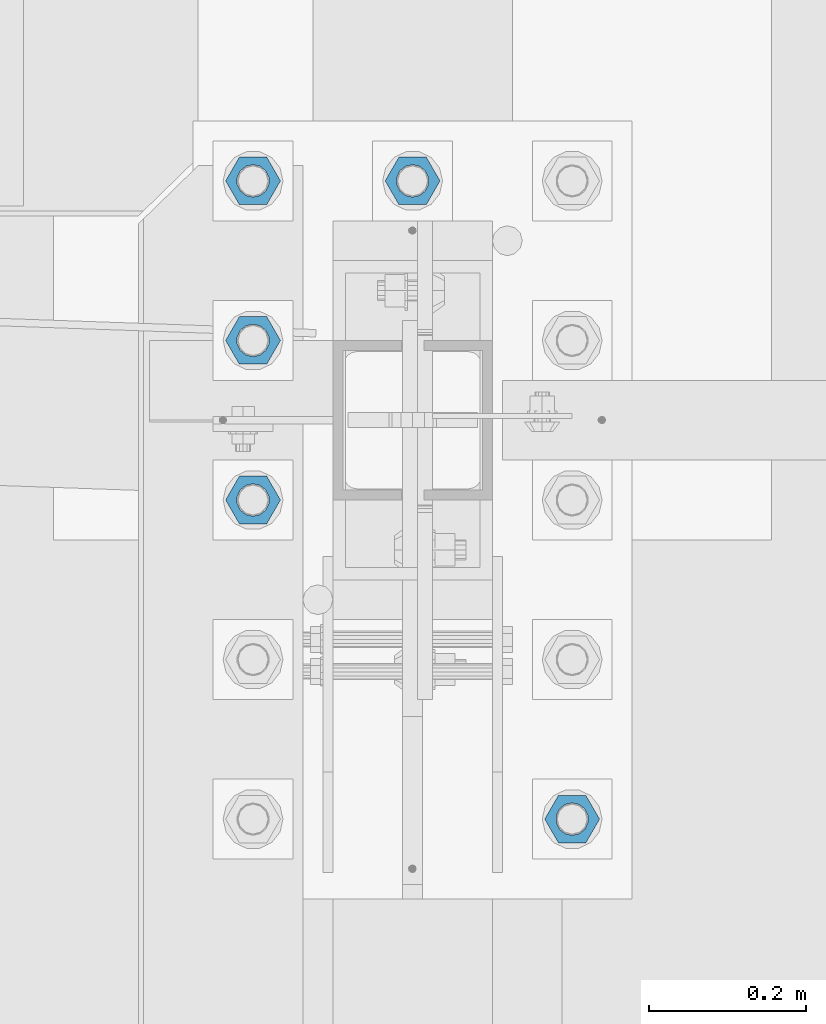
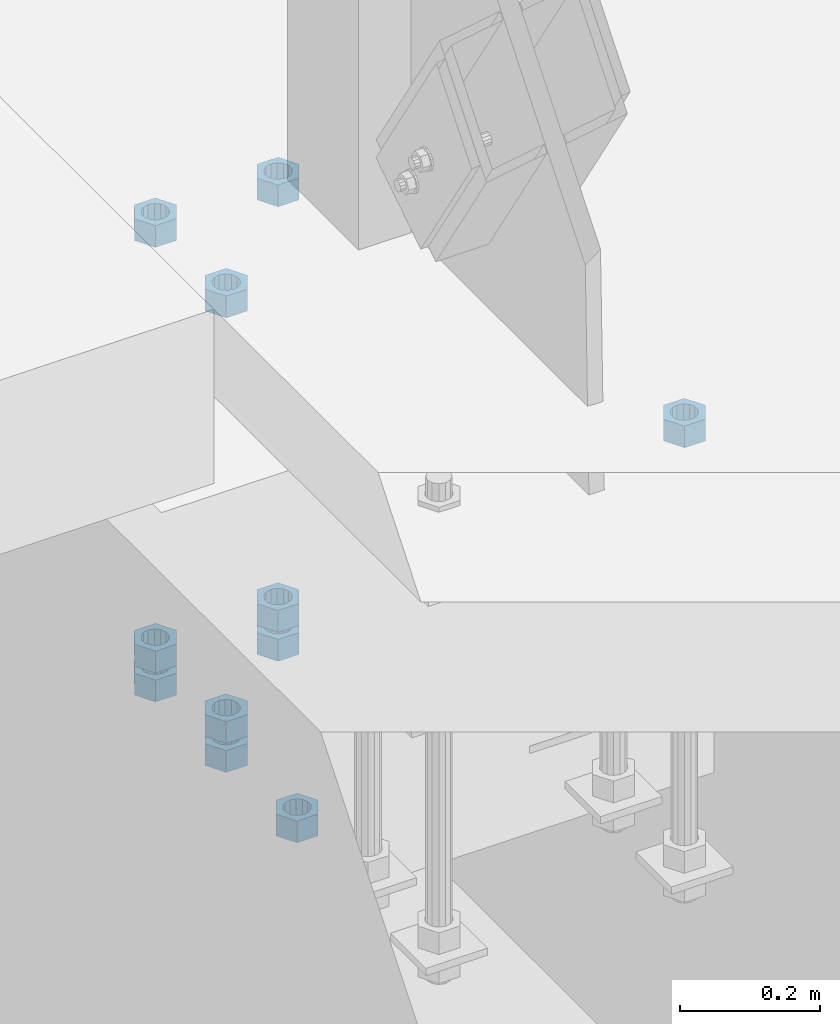
# One storey, part 988 of 1763: 11 columns, 1 element without a shape of its own.
"""IFC2X3 building model written with IfcOpenShell, lengths in millimetres."""

from ifc_helpers import new_model, si_unit, frame, origin_with_axes, place, context, subcontext, project, spatial, faceted_brep, material, type_object, element, aggregate, save


model = new_model("IFC2X3")

# Units and contexts
model_context = context("Model", 3, precision=1e-05, world=origin_with_axes())
body_context = subcontext(model_context, "Body", "Model", "MODEL_VIEW")
ifc_project = project(units=[si_unit("LENGTHUNIT", "METRE", prefix="MILLI"), si_unit("AREAUNIT", "SQUARE_METRE"), si_unit("VOLUMEUNIT", "CUBIC_METRE"), si_unit("MASSUNIT", "GRAM", prefix="KILO"), si_unit("TIMEUNIT", "SECOND"), si_unit("PLANEANGLEUNIT", "RADIAN"), si_unit("SOLIDANGLEUNIT", "STERADIAN"), si_unit("THERMODYNAMICTEMPERATUREUNIT", "DEGREE_CELSIUS"), si_unit("LUMINOUSINTENSITYUNIT", "LUMEN")], contexts=[model_context])

# Site, building, storey
site_placement = place(None, origin_with_axes())
site = spatial("IfcSite", under=ifc_project, at=site_placement, CompositionType="ELEMENT")
building_placement = place(site_placement, origin_with_axes())
building = spatial("IfcBuilding", under=site, at=building_placement, Name="Undefined", CompositionType="ELEMENT")
storey_placement = place(building_placement, origin_with_axes())
storey = spatial("IfcBuildingStorey", under=building, at=storey_placement, Name="Undefined", CompositionType="ELEMENT", Elevation=0.0)

# Assembly, columns
assembly_placement = place(storey_placement, origin_with_axes())
assembly = element("IfcElementAssembly", 1, at=assembly_placement, inside=storey, Name="TEMPLATE", AssemblyPlace="NOTDEFINED", PredefinedType="RIGID_FRAME")
ifc_material = material(Name="STEEL/A563")
column_type = type_object("IfcColumnType", Name="1-1/2_HEAVY_HEX_NUT", PredefinedType="NOTDEFINED")
column_1_placement = place(assembly_placement, frame((-87172.2372736984, 8026.40000000001, 5189.53750000001), z_axis=(0.0, 1.0, 0.0), x_axis=(0.0, 0.0, -1.0)))
column_1 = element("IfcColumn", 2, at=column_1_placement, type_object=column_type, material=ifc_material, Name="NUT", ObjectType="1-1/2_HEAVY_HEX_NUT", context=body_context, shape_type="Brep", body=[
    faceted_brep([(0.0, -34.9199981689453, 0.0), (0.0, -17.4599990844727, -30.25), (38.1000000000004, -17.4599990844727, -30.25), (38.1000000000004, -34.9199981689453, 0.0), (0.0, 17.4599990844727, -30.25), (38.1000000000004, 17.4599990844727, -30.25), (0.0, 34.9199981689453, 0.0), (38.1000000000004, 34.9199981689453, 0.0), (0.0, 17.4599990844727, 30.25), (38.1000000000004, 17.4599990844727, 30.25), (0.0, -17.4599990844727, 30.25), (38.1000000000004, -17.4599990844727, 30.25), (0.0, 0.0, 20.6399993896484), (0.0, 8.95536011056538, 18.5959968835978), (38.1000000000004, 8.95536011056538, 18.5959968835978), (38.1000000000004, 0.0, 20.6399993896484), (0.0, 16.1370013209453, 12.8688291298167), (38.1000000000004, 16.1370013209453, 12.8688291298167), (0.0, 20.1225115123816, 4.59283194104137), (38.1000000000004, 20.1225115123816, 4.59283194104137), (0.0, 20.1225115123816, -4.59283194104319), (38.1000000000004, 20.1225115123816, -4.59283194104319), (0.0, 16.1370013209453, -12.8688291298167), (38.1000000000004, 16.1370013209453, -12.8688291298167), (0.0, 8.95536011056538, -18.5959968835978), (38.1000000000004, 8.95536011056538, -18.5959968835978), (0.0, 0.0, -20.6399993896484), (38.1000000000004, 0.0, -20.6399993896484), (0.0, -8.95536011056538, -18.5959968835978), (38.1000000000004, -8.95536011056538, -18.5959968835978), (0.0, -16.1370013209453, -12.8688291298167), (38.1000000000004, -16.1370013209453, -12.8688291298167), (0.0, -20.1225115123816, -4.59283194104137), (38.1000000000004, -20.1225115123816, -4.59283194104137), (0.0, -20.1225115123816, 4.59283194104319), (38.1000000000004, -20.1225115123816, 4.59283194104319), (0.0, -16.1370013209453, 12.8688291298167), (38.1000000000004, -16.1370013209453, 12.8688291298167), (0.0, -8.95536011056538, 18.5959968835978), (38.1000000000004, -8.95536011056538, 18.5959968835978)], [[[0, 1, 2, 3]], [[1, 4, 5, 2]], [[4, 6, 7, 5]], [[6, 8, 9, 7]], [[8, 10, 11, 9]], [[10, 0, 3, 11]], [[12, 13, 14, 15]], [[13, 16, 17, 14]], [[16, 18, 19, 17]], [[18, 20, 21, 19]], [[20, 22, 23, 21]], [[22, 24, 25, 23]], [[24, 26, 27, 25]], [[26, 28, 29, 27]], [[28, 30, 31, 29]], [[30, 32, 33, 31]], [[32, 34, 35, 33]], [[34, 36, 37, 35]], [[36, 38, 39, 37]], [[38, 12, 15, 39]], [[5, 7, 9, 11, 3, 2], [17, 19, 21, 23, 25, 27, 29, 31, 33, 35, 37, 39, 15, 14]], [[10, 8, 6, 4, 1, 0], [38, 36, 34, 32, 30, 28, 26, 24, 22, 20, 18, 16, 13, 12]]]),
])
column_2_placement = place(assembly_placement, frame((-87578.6372736983, 8432.80000000001, 4394.20000000001), z_axis=(0.0, -1.0, 0.0), x_axis=(0.0, 0.0, -1.0)))
column_2 = element("IfcColumn", 3, at=column_2_placement, type_object=column_type, material=ifc_material, Name="NUT", ObjectType="1-1/2_HEAVY_HEX_NUT", context=body_context, shape_type="Brep", body=[
    faceted_brep([(0.0, -34.9199981689453, 0.0), (0.0, -17.4599990844727, -30.25), (38.1000000000004, -17.4599990844727, -30.25), (38.1000000000004, -34.9199981689453, 0.0), (0.0, 17.4599990844727, -30.25), (38.1000000000004, 17.4599990844727, -30.25), (0.0, 34.9199981689453, 0.0), (38.1000000000004, 34.9199981689453, 0.0), (0.0, 17.4599990844727, 30.25), (38.1000000000004, 17.4599990844727, 30.25), (0.0, -17.4599990844727, 30.25), (38.1000000000004, -17.4599990844727, 30.25), (0.0, 0.0, 20.6399993896484), (0.0, 8.95536011056538, 18.5959968835978), (38.1000000000004, 8.95536011056538, 18.5959968835978), (38.1000000000004, 0.0, 20.6399993896484), (0.0, 16.1370013209453, 12.8688291298167), (38.1000000000004, 16.1370013209453, 12.8688291298167), (0.0, 20.1225115123816, 4.59283194104137), (38.1000000000004, 20.1225115123816, 4.59283194104137), (0.0, 20.1225115123816, -4.59283194104319), (38.1000000000004, 20.1225115123816, -4.59283194104319), (0.0, 16.1370013209453, -12.8688291298167), (38.1000000000004, 16.1370013209453, -12.8688291298167), (0.0, 8.95536011056538, -18.5959968835978), (38.1000000000004, 8.95536011056538, -18.5959968835978), (0.0, 0.0, -20.6399993896484), (38.1000000000004, 0.0, -20.6399993896484), (0.0, -8.95536011056538, -18.5959968835978), (38.1000000000004, -8.95536011056538, -18.5959968835978), (0.0, -16.1370013209453, -12.8688291298167), (38.1000000000004, -16.1370013209453, -12.8688291298167), (0.0, -20.1225115123816, -4.59283194104137), (38.1000000000004, -20.1225115123816, -4.59283194104137), (0.0, -20.1225115123816, 4.59283194104319), (38.1000000000004, -20.1225115123816, 4.59283194104319), (0.0, -16.1370013209453, 12.8688291298167), (38.1000000000004, -16.1370013209453, 12.8688291298167), (0.0, -8.95536011056538, 18.5959968835978), (38.1000000000004, -8.95536011056538, 18.5959968835978)], [[[0, 1, 2, 3]], [[1, 4, 5, 2]], [[4, 6, 7, 5]], [[6, 8, 9, 7]], [[8, 10, 11, 9]], [[10, 0, 3, 11]], [[12, 13, 14, 15]], [[13, 16, 17, 14]], [[16, 18, 19, 17]], [[18, 20, 21, 19]], [[20, 22, 23, 21]], [[22, 24, 25, 23]], [[24, 26, 27, 25]], [[26, 28, 29, 27]], [[28, 30, 31, 29]], [[30, 32, 33, 31]], [[32, 34, 35, 33]], [[34, 36, 37, 35]], [[36, 38, 39, 37]], [[38, 12, 15, 39]], [[5, 7, 9, 11, 3, 2], [17, 19, 21, 23, 25, 27, 29, 31, 33, 35, 37, 39, 15, 14]], [[10, 8, 6, 4, 1, 0], [38, 36, 34, 32, 30, 28, 26, 24, 22, 20, 18, 16, 13, 12]]]),
])
column_3_placement = place(assembly_placement, frame((-87578.6372736983, 8636.00000000001, 5189.53750000001), z_axis=(0.0, -1.0, 0.0), x_axis=(0.0, 0.0, -1.0)))
column_3 = element("IfcColumn", 4, at=column_3_placement, type_object=column_type, material=ifc_material, Name="NUT", ObjectType="1-1/2_HEAVY_HEX_NUT", context=body_context, shape_type="Brep", body=[
    faceted_brep([(0.0, -34.9199981689453, 0.0), (0.0, -17.4599990844727, -30.25), (38.1000000000004, -17.4599990844727, -30.25), (38.1000000000004, -34.9199981689453, 0.0), (0.0, 17.4599990844727, -30.25), (38.1000000000004, 17.4599990844727, -30.25), (0.0, 34.9199981689453, 0.0), (38.1000000000004, 34.9199981689453, 0.0), (0.0, 17.4599990844727, 30.25), (38.1000000000004, 17.4599990844727, 30.25), (0.0, -17.4599990844727, 30.25), (38.1000000000004, -17.4599990844727, 30.25), (0.0, 0.0, 20.6399993896484), (0.0, 8.95536011056538, 18.5959968835978), (38.1000000000004, 8.95536011056538, 18.5959968835978), (38.1000000000004, 0.0, 20.6399993896484), (0.0, 16.1370013209453, 12.8688291298167), (38.1000000000004, 16.1370013209453, 12.8688291298167), (0.0, 20.1225115123816, 4.59283194104137), (38.1000000000004, 20.1225115123816, 4.59283194104137), (0.0, 20.1225115123816, -4.59283194104319), (38.1000000000004, 20.1225115123816, -4.59283194104319), (0.0, 16.1370013209453, -12.8688291298167), (38.1000000000004, 16.1370013209453, -12.8688291298167), (0.0, 8.95536011056538, -18.5959968835978), (38.1000000000004, 8.95536011056538, -18.5959968835978), (0.0, 0.0, -20.6399993896484), (38.1000000000004, 0.0, -20.6399993896484), (0.0, -8.95536011056538, -18.5959968835978), (38.1000000000004, -8.95536011056538, -18.5959968835978), (0.0, -16.1370013209453, -12.8688291298167), (38.1000000000004, -16.1370013209453, -12.8688291298167), (0.0, -20.1225115123816, -4.59283194104137), (38.1000000000004, -20.1225115123816, -4.59283194104137), (0.0, -20.1225115123816, 4.59283194104319), (38.1000000000004, -20.1225115123816, 4.59283194104319), (0.0, -16.1370013209453, 12.8688291298167), (38.1000000000004, -16.1370013209453, 12.8688291298167), (0.0, -8.95536011056538, 18.5959968835978), (38.1000000000004, -8.95536011056538, 18.5959968835978)], [[[0, 1, 2, 3]], [[1, 4, 5, 2]], [[4, 6, 7, 5]], [[6, 8, 9, 7]], [[8, 10, 11, 9]], [[10, 0, 3, 11]], [[12, 13, 14, 15]], [[13, 16, 17, 14]], [[16, 18, 19, 17]], [[18, 20, 21, 19]], [[20, 22, 23, 21]], [[22, 24, 25, 23]], [[24, 26, 27, 25]], [[26, 28, 29, 27]], [[28, 30, 31, 29]], [[30, 32, 33, 31]], [[32, 34, 35, 33]], [[34, 36, 37, 35]], [[36, 38, 39, 37]], [[38, 12, 15, 39]], [[5, 7, 9, 11, 3, 2], [17, 19, 21, 23, 25, 27, 29, 31, 33, 35, 37, 39, 15, 14]], [[10, 8, 6, 4, 1, 0], [38, 36, 34, 32, 30, 28, 26, 24, 22, 20, 18, 16, 13, 12]]]),
])
column_4_placement = place(assembly_placement, frame((-87578.6372736983, 8636.00000000001, 4445.00000000001), z_axis=(0.0, -1.0, 0.0), x_axis=(0.0, 0.0, -1.0)))
column_4 = element("IfcColumn", 5, at=column_4_placement, type_object=column_type, material=ifc_material, Name="NUT", ObjectType="1-1/2_HEAVY_HEX_NUT", context=body_context, shape_type="Brep", body=[
    faceted_brep([(0.0, -34.9199981689453, 0.0), (0.0, -17.4599990844727, -30.25), (38.1000000000004, -17.4599990844727, -30.25), (38.1000000000004, -34.9199981689453, 0.0), (0.0, 17.4599990844727, -30.25), (38.1000000000004, 17.4599990844727, -30.25), (0.0, 34.9199981689453, 0.0), (38.1000000000004, 34.9199981689453, 0.0), (0.0, 17.4599990844727, 30.25), (38.1000000000004, 17.4599990844727, 30.25), (0.0, -17.4599990844727, 30.25), (38.1000000000004, -17.4599990844727, 30.25), (0.0, 0.0, 20.6399993896484), (0.0, 8.95536011056538, 18.5959968835978), (38.1000000000004, 8.95536011056538, 18.5959968835978), (38.1000000000004, 0.0, 20.6399993896484), (0.0, 16.1370013209453, 12.8688291298167), (38.1000000000004, 16.1370013209453, 12.8688291298167), (0.0, 20.1225115123816, 4.59283194104137), (38.1000000000004, 20.1225115123816, 4.59283194104137), (0.0, 20.1225115123816, -4.59283194104319), (38.1000000000004, 20.1225115123816, -4.59283194104319), (0.0, 16.1370013209453, -12.8688291298167), (38.1000000000004, 16.1370013209453, -12.8688291298167), (0.0, 8.95536011056538, -18.5959968835978), (38.1000000000004, 8.95536011056538, -18.5959968835978), (0.0, 0.0, -20.6399993896484), (38.1000000000004, 0.0, -20.6399993896484), (0.0, -8.95536011056538, -18.5959968835978), (38.1000000000004, -8.95536011056538, -18.5959968835978), (0.0, -16.1370013209453, -12.8688291298167), (38.1000000000004, -16.1370013209453, -12.8688291298167), (0.0, -20.1225115123816, -4.59283194104137), (38.1000000000004, -20.1225115123816, -4.59283194104137), (0.0, -20.1225115123816, 4.59283194104319), (38.1000000000004, -20.1225115123816, 4.59283194104319), (0.0, -16.1370013209453, 12.8688291298167), (38.1000000000004, -16.1370013209453, 12.8688291298167), (0.0, -8.95536011056538, 18.5959968835978), (38.1000000000004, -8.95536011056538, 18.5959968835978)], [[[0, 1, 2, 3]], [[1, 4, 5, 2]], [[4, 6, 7, 5]], [[6, 8, 9, 7]], [[8, 10, 11, 9]], [[10, 0, 3, 11]], [[12, 13, 14, 15]], [[13, 16, 17, 14]], [[16, 18, 19, 17]], [[18, 20, 21, 19]], [[20, 22, 23, 21]], [[22, 24, 25, 23]], [[24, 26, 27, 25]], [[26, 28, 29, 27]], [[28, 30, 31, 29]], [[30, 32, 33, 31]], [[32, 34, 35, 33]], [[34, 36, 37, 35]], [[36, 38, 39, 37]], [[38, 12, 15, 39]], [[5, 7, 9, 11, 3, 2], [17, 19, 21, 23, 25, 27, 29, 31, 33, 35, 37, 39, 15, 14]], [[10, 8, 6, 4, 1, 0], [38, 36, 34, 32, 30, 28, 26, 24, 22, 20, 18, 16, 13, 12]]]),
])
column_5_placement = place(assembly_placement, frame((-87578.6372736983, 8636.00000000001, 4394.20000000001), z_axis=(0.0, -1.0, 0.0), x_axis=(0.0, 0.0, -1.0)))
column_5 = element("IfcColumn", 6, at=column_5_placement, type_object=column_type, material=ifc_material, Name="NUT", ObjectType="1-1/2_HEAVY_HEX_NUT", context=body_context, shape_type="Brep", body=[
    faceted_brep([(0.0, -34.9199981689453, 0.0), (0.0, -17.4599990844727, -30.25), (38.1000000000004, -17.4599990844727, -30.25), (38.1000000000004, -34.9199981689453, 0.0), (0.0, 17.4599990844727, -30.25), (38.1000000000004, 17.4599990844727, -30.25), (0.0, 34.9199981689453, 0.0), (38.1000000000004, 34.9199981689453, 0.0), (0.0, 17.4599990844727, 30.25), (38.1000000000004, 17.4599990844727, 30.25), (0.0, -17.4599990844727, 30.25), (38.1000000000004, -17.4599990844727, 30.25), (0.0, 0.0, 20.6399993896484), (0.0, 8.95536011056538, 18.5959968835978), (38.1000000000004, 8.95536011056538, 18.5959968835978), (38.1000000000004, 0.0, 20.6399993896484), (0.0, 16.1370013209453, 12.8688291298167), (38.1000000000004, 16.1370013209453, 12.8688291298167), (0.0, 20.1225115123816, 4.59283194104137), (38.1000000000004, 20.1225115123816, 4.59283194104137), (0.0, 20.1225115123816, -4.59283194104319), (38.1000000000004, 20.1225115123816, -4.59283194104319), (0.0, 16.1370013209453, -12.8688291298167), (38.1000000000004, 16.1370013209453, -12.8688291298167), (0.0, 8.95536011056538, -18.5959968835978), (38.1000000000004, 8.95536011056538, -18.5959968835978), (0.0, 0.0, -20.6399993896484), (38.1000000000004, 0.0, -20.6399993896484), (0.0, -8.95536011056538, -18.5959968835978), (38.1000000000004, -8.95536011056538, -18.5959968835978), (0.0, -16.1370013209453, -12.8688291298167), (38.1000000000004, -16.1370013209453, -12.8688291298167), (0.0, -20.1225115123816, -4.59283194104137), (38.1000000000004, -20.1225115123816, -4.59283194104137), (0.0, -20.1225115123816, 4.59283194104319), (38.1000000000004, -20.1225115123816, 4.59283194104319), (0.0, -16.1370013209453, 12.8688291298167), (38.1000000000004, -16.1370013209453, 12.8688291298167), (0.0, -8.95536011056538, 18.5959968835978), (38.1000000000004, -8.95536011056538, 18.5959968835978)], [[[0, 1, 2, 3]], [[1, 4, 5, 2]], [[4, 6, 7, 5]], [[6, 8, 9, 7]], [[8, 10, 11, 9]], [[10, 0, 3, 11]], [[12, 13, 14, 15]], [[13, 16, 17, 14]], [[16, 18, 19, 17]], [[18, 20, 21, 19]], [[20, 22, 23, 21]], [[22, 24, 25, 23]], [[24, 26, 27, 25]], [[26, 28, 29, 27]], [[28, 30, 31, 29]], [[30, 32, 33, 31]], [[32, 34, 35, 33]], [[34, 36, 37, 35]], [[36, 38, 39, 37]], [[38, 12, 15, 39]], [[5, 7, 9, 11, 3, 2], [17, 19, 21, 23, 25, 27, 29, 31, 33, 35, 37, 39, 15, 14]], [[10, 8, 6, 4, 1, 0], [38, 36, 34, 32, 30, 28, 26, 24, 22, 20, 18, 16, 13, 12]]]),
])
column_6_placement = place(assembly_placement, frame((-87578.6372736983, 8839.20000000001, 5189.53750000001), z_axis=(0.0, -1.0, 0.0), x_axis=(0.0, 0.0, -1.0)))
column_6 = element("IfcColumn", 7, at=column_6_placement, type_object=column_type, material=ifc_material, Name="NUT", ObjectType="1-1/2_HEAVY_HEX_NUT", context=body_context, shape_type="Brep", body=[
    faceted_brep([(0.0, -34.9199981689453, 0.0), (0.0, -17.4599990844727, -30.25), (38.1000000000004, -17.4599990844727, -30.25), (38.1000000000004, -34.9199981689453, 0.0), (0.0, 17.4599990844727, -30.25), (38.1000000000004, 17.4599990844727, -30.25), (0.0, 34.9199981689453, 0.0), (38.1000000000004, 34.9199981689453, 0.0), (0.0, 17.4599990844727, 30.25), (38.1000000000004, 17.4599990844727, 30.25), (0.0, -17.4599990844727, 30.25), (38.1000000000004, -17.4599990844727, 30.25), (0.0, 0.0, 20.6399993896484), (0.0, 8.95536011056538, 18.5959968835978), (38.1000000000004, 8.95536011056538, 18.5959968835978), (38.1000000000004, 0.0, 20.6399993896484), (0.0, 16.1370013209453, 12.8688291298167), (38.1000000000004, 16.1370013209453, 12.8688291298167), (0.0, 20.1225115123816, 4.59283194104137), (38.1000000000004, 20.1225115123816, 4.59283194104137), (0.0, 20.1225115123816, -4.59283194104319), (38.1000000000004, 20.1225115123816, -4.59283194104319), (0.0, 16.1370013209453, -12.8688291298167), (38.1000000000004, 16.1370013209453, -12.8688291298167), (0.0, 8.95536011056538, -18.5959968835978), (38.1000000000004, 8.95536011056538, -18.5959968835978), (0.0, 0.0, -20.6399993896484), (38.1000000000004, 0.0, -20.6399993896484), (0.0, -8.95536011056538, -18.5959968835978), (38.1000000000004, -8.95536011056538, -18.5959968835978), (0.0, -16.1370013209453, -12.8688291298167), (38.1000000000004, -16.1370013209453, -12.8688291298167), (0.0, -20.1225115123816, -4.59283194104137), (38.1000000000004, -20.1225115123816, -4.59283194104137), (0.0, -20.1225115123816, 4.59283194104319), (38.1000000000004, -20.1225115123816, 4.59283194104319), (0.0, -16.1370013209453, 12.8688291298167), (38.1000000000004, -16.1370013209453, 12.8688291298167), (0.0, -8.95536011056538, 18.5959968835978), (38.1000000000004, -8.95536011056538, 18.5959968835978)], [[[0, 1, 2, 3]], [[1, 4, 5, 2]], [[4, 6, 7, 5]], [[6, 8, 9, 7]], [[8, 10, 11, 9]], [[10, 0, 3, 11]], [[12, 13, 14, 15]], [[13, 16, 17, 14]], [[16, 18, 19, 17]], [[18, 20, 21, 19]], [[20, 22, 23, 21]], [[22, 24, 25, 23]], [[24, 26, 27, 25]], [[26, 28, 29, 27]], [[28, 30, 31, 29]], [[30, 32, 33, 31]], [[32, 34, 35, 33]], [[34, 36, 37, 35]], [[36, 38, 39, 37]], [[38, 12, 15, 39]], [[5, 7, 9, 11, 3, 2], [17, 19, 21, 23, 25, 27, 29, 31, 33, 35, 37, 39, 15, 14]], [[10, 8, 6, 4, 1, 0], [38, 36, 34, 32, 30, 28, 26, 24, 22, 20, 18, 16, 13, 12]]]),
])
column_7_placement = place(assembly_placement, frame((-87578.6372736983, 8839.20000000001, 4445.00000000001), z_axis=(0.0, -1.0, 0.0), x_axis=(0.0, 0.0, -1.0)))
column_7 = element("IfcColumn", 8, at=column_7_placement, type_object=column_type, material=ifc_material, Name="NUT", ObjectType="1-1/2_HEAVY_HEX_NUT", context=body_context, shape_type="Brep", body=[
    faceted_brep([(0.0, -34.9199981689453, 0.0), (0.0, -17.4599990844727, -30.25), (38.1000000000004, -17.4599990844727, -30.25), (38.1000000000004, -34.9199981689453, 0.0), (0.0, 17.4599990844727, -30.25), (38.1000000000004, 17.4599990844727, -30.25), (0.0, 34.9199981689453, 0.0), (38.1000000000004, 34.9199981689453, 0.0), (0.0, 17.4599990844727, 30.25), (38.1000000000004, 17.4599990844727, 30.25), (0.0, -17.4599990844727, 30.25), (38.1000000000004, -17.4599990844727, 30.25), (0.0, 0.0, 20.6399993896484), (0.0, 8.95536011056538, 18.5959968835978), (38.1000000000004, 8.95536011056538, 18.5959968835978), (38.1000000000004, 0.0, 20.6399993896484), (0.0, 16.1370013209453, 12.8688291298167), (38.1000000000004, 16.1370013209453, 12.8688291298167), (0.0, 20.1225115123816, 4.59283194104137), (38.1000000000004, 20.1225115123816, 4.59283194104137), (0.0, 20.1225115123816, -4.59283194104319), (38.1000000000004, 20.1225115123816, -4.59283194104319), (0.0, 16.1370013209453, -12.8688291298167), (38.1000000000004, 16.1370013209453, -12.8688291298167), (0.0, 8.95536011056538, -18.5959968835978), (38.1000000000004, 8.95536011056538, -18.5959968835978), (0.0, 0.0, -20.6399993896484), (38.1000000000004, 0.0, -20.6399993896484), (0.0, -8.95536011056538, -18.5959968835978), (38.1000000000004, -8.95536011056538, -18.5959968835978), (0.0, -16.1370013209453, -12.8688291298167), (38.1000000000004, -16.1370013209453, -12.8688291298167), (0.0, -20.1225115123816, -4.59283194104137), (38.1000000000004, -20.1225115123816, -4.59283194104137), (0.0, -20.1225115123816, 4.59283194104319), (38.1000000000004, -20.1225115123816, 4.59283194104319), (0.0, -16.1370013209453, 12.8688291298167), (38.1000000000004, -16.1370013209453, 12.8688291298167), (0.0, -8.95536011056538, 18.5959968835978), (38.1000000000004, -8.95536011056538, 18.5959968835978)], [[[0, 1, 2, 3]], [[1, 4, 5, 2]], [[4, 6, 7, 5]], [[6, 8, 9, 7]], [[8, 10, 11, 9]], [[10, 0, 3, 11]], [[12, 13, 14, 15]], [[13, 16, 17, 14]], [[16, 18, 19, 17]], [[18, 20, 21, 19]], [[20, 22, 23, 21]], [[22, 24, 25, 23]], [[24, 26, 27, 25]], [[26, 28, 29, 27]], [[28, 30, 31, 29]], [[30, 32, 33, 31]], [[32, 34, 35, 33]], [[34, 36, 37, 35]], [[36, 38, 39, 37]], [[38, 12, 15, 39]], [[5, 7, 9, 11, 3, 2], [17, 19, 21, 23, 25, 27, 29, 31, 33, 35, 37, 39, 15, 14]], [[10, 8, 6, 4, 1, 0], [38, 36, 34, 32, 30, 28, 26, 24, 22, 20, 18, 16, 13, 12]]]),
])
column_8_placement = place(assembly_placement, frame((-87578.6372736983, 8839.20000000001, 4394.20000000001), z_axis=(0.0, -1.0, 0.0), x_axis=(0.0, 0.0, -1.0)))
column_8 = element("IfcColumn", 9, at=column_8_placement, type_object=column_type, material=ifc_material, Name="NUT", ObjectType="1-1/2_HEAVY_HEX_NUT", context=body_context, shape_type="Brep", body=[
    faceted_brep([(0.0, -34.9199981689453, 0.0), (0.0, -17.4599990844727, -30.25), (38.1000000000004, -17.4599990844727, -30.25), (38.1000000000004, -34.9199981689453, 0.0), (0.0, 17.4599990844727, -30.25), (38.1000000000004, 17.4599990844727, -30.25), (0.0, 34.9199981689453, 0.0), (38.1000000000004, 34.9199981689453, 0.0), (0.0, 17.4599990844727, 30.25), (38.1000000000004, 17.4599990844727, 30.25), (0.0, -17.4599990844727, 30.25), (38.1000000000004, -17.4599990844727, 30.25), (0.0, 0.0, 20.6399993896484), (0.0, 8.95536011056538, 18.5959968835978), (38.1000000000004, 8.95536011056538, 18.5959968835978), (38.1000000000004, 0.0, 20.6399993896484), (0.0, 16.1370013209453, 12.8688291298167), (38.1000000000004, 16.1370013209453, 12.8688291298167), (0.0, 20.1225115123816, 4.59283194104137), (38.1000000000004, 20.1225115123816, 4.59283194104137), (0.0, 20.1225115123816, -4.59283194104319), (38.1000000000004, 20.1225115123816, -4.59283194104319), (0.0, 16.1370013209453, -12.8688291298167), (38.1000000000004, 16.1370013209453, -12.8688291298167), (0.0, 8.95536011056538, -18.5959968835978), (38.1000000000004, 8.95536011056538, -18.5959968835978), (0.0, 0.0, -20.6399993896484), (38.1000000000004, 0.0, -20.6399993896484), (0.0, -8.95536011056538, -18.5959968835978), (38.1000000000004, -8.95536011056538, -18.5959968835978), (0.0, -16.1370013209453, -12.8688291298167), (38.1000000000004, -16.1370013209453, -12.8688291298167), (0.0, -20.1225115123816, -4.59283194104137), (38.1000000000004, -20.1225115123816, -4.59283194104137), (0.0, -20.1225115123816, 4.59283194104319), (38.1000000000004, -20.1225115123816, 4.59283194104319), (0.0, -16.1370013209453, 12.8688291298167), (38.1000000000004, -16.1370013209453, 12.8688291298167), (0.0, -8.95536011056538, 18.5959968835978), (38.1000000000004, -8.95536011056538, 18.5959968835978)], [[[0, 1, 2, 3]], [[1, 4, 5, 2]], [[4, 6, 7, 5]], [[6, 8, 9, 7]], [[8, 10, 11, 9]], [[10, 0, 3, 11]], [[12, 13, 14, 15]], [[13, 16, 17, 14]], [[16, 18, 19, 17]], [[18, 20, 21, 19]], [[20, 22, 23, 21]], [[22, 24, 25, 23]], [[24, 26, 27, 25]], [[26, 28, 29, 27]], [[28, 30, 31, 29]], [[30, 32, 33, 31]], [[32, 34, 35, 33]], [[34, 36, 37, 35]], [[36, 38, 39, 37]], [[38, 12, 15, 39]], [[5, 7, 9, 11, 3, 2], [17, 19, 21, 23, 25, 27, 29, 31, 33, 35, 37, 39, 15, 14]], [[10, 8, 6, 4, 1, 0], [38, 36, 34, 32, 30, 28, 26, 24, 22, 20, 18, 16, 13, 12]]]),
])
column_9_placement = place(assembly_placement, frame((-87375.4372736983, 8839.20000000001, 5189.53750000001), z_axis=(0.0, -1.0, 0.0), x_axis=(0.0, 0.0, -1.0)))
column_9 = element("IfcColumn", 10, at=column_9_placement, type_object=column_type, material=ifc_material, Name="NUT", ObjectType="1-1/2_HEAVY_HEX_NUT", context=body_context, shape_type="Brep", body=[
    faceted_brep([(0.0, -34.9199981689453, 0.0), (0.0, -17.4599990844727, -30.25), (38.1000000000004, -17.4599990844727, -30.25), (38.1000000000004, -34.9199981689453, 0.0), (0.0, 17.4599990844727, -30.25), (38.1000000000004, 17.4599990844727, -30.25), (0.0, 34.9199981689453, 0.0), (38.1000000000004, 34.9199981689453, 0.0), (0.0, 17.4599990844727, 30.25), (38.1000000000004, 17.4599990844727, 30.25), (0.0, -17.4599990844727, 30.25), (38.1000000000004, -17.4599990844727, 30.25), (0.0, 0.0, 20.6399993896484), (0.0, 8.95536011056538, 18.5959968835978), (38.1000000000004, 8.95536011056538, 18.5959968835978), (38.1000000000004, 0.0, 20.6399993896484), (0.0, 16.1370013209453, 12.8688291298167), (38.1000000000004, 16.1370013209453, 12.8688291298167), (0.0, 20.1225115123816, 4.59283194104137), (38.1000000000004, 20.1225115123816, 4.59283194104137), (0.0, 20.1225115123816, -4.59283194104319), (38.1000000000004, 20.1225115123816, -4.59283194104319), (0.0, 16.1370013209453, -12.8688291298167), (38.1000000000004, 16.1370013209453, -12.8688291298167), (0.0, 8.95536011056538, -18.5959968835978), (38.1000000000004, 8.95536011056538, -18.5959968835978), (0.0, 0.0, -20.6399993896484), (38.1000000000004, 0.0, -20.6399993896484), (0.0, -8.95536011056538, -18.5959968835978), (38.1000000000004, -8.95536011056538, -18.5959968835978), (0.0, -16.1370013209453, -12.8688291298167), (38.1000000000004, -16.1370013209453, -12.8688291298167), (0.0, -20.1225115123816, -4.59283194104137), (38.1000000000004, -20.1225115123816, -4.59283194104137), (0.0, -20.1225115123816, 4.59283194104319), (38.1000000000004, -20.1225115123816, 4.59283194104319), (0.0, -16.1370013209453, 12.8688291298167), (38.1000000000004, -16.1370013209453, 12.8688291298167), (0.0, -8.95536011056538, 18.5959968835978), (38.1000000000004, -8.95536011056538, 18.5959968835978)], [[[0, 1, 2, 3]], [[1, 4, 5, 2]], [[4, 6, 7, 5]], [[6, 8, 9, 7]], [[8, 10, 11, 9]], [[10, 0, 3, 11]], [[12, 13, 14, 15]], [[13, 16, 17, 14]], [[16, 18, 19, 17]], [[18, 20, 21, 19]], [[20, 22, 23, 21]], [[22, 24, 25, 23]], [[24, 26, 27, 25]], [[26, 28, 29, 27]], [[28, 30, 31, 29]], [[30, 32, 33, 31]], [[32, 34, 35, 33]], [[34, 36, 37, 35]], [[36, 38, 39, 37]], [[38, 12, 15, 39]], [[5, 7, 9, 11, 3, 2], [17, 19, 21, 23, 25, 27, 29, 31, 33, 35, 37, 39, 15, 14]], [[10, 8, 6, 4, 1, 0], [38, 36, 34, 32, 30, 28, 26, 24, 22, 20, 18, 16, 13, 12]]]),
])
column_10_placement = place(assembly_placement, frame((-87375.4372736983, 8839.20000000001, 4445.00000000001), z_axis=(0.0, -1.0, 0.0), x_axis=(0.0, 0.0, -1.0)))
column_10 = element("IfcColumn", 11, at=column_10_placement, type_object=column_type, material=ifc_material, Name="NUT", ObjectType="1-1/2_HEAVY_HEX_NUT", context=body_context, shape_type="Brep", body=[
    faceted_brep([(0.0, -34.9199981689453, 0.0), (0.0, -17.4599990844727, -30.25), (38.1000000000004, -17.4599990844727, -30.25), (38.1000000000004, -34.9199981689453, 0.0), (0.0, 17.4599990844727, -30.25), (38.1000000000004, 17.4599990844727, -30.25), (0.0, 34.9199981689453, 0.0), (38.1000000000004, 34.9199981689453, 0.0), (0.0, 17.4599990844727, 30.25), (38.1000000000004, 17.4599990844727, 30.25), (0.0, -17.4599990844727, 30.25), (38.1000000000004, -17.4599990844727, 30.25), (0.0, 0.0, 20.6399993896484), (0.0, 8.95536011056538, 18.5959968835978), (38.1000000000004, 8.95536011056538, 18.5959968835978), (38.1000000000004, 0.0, 20.6399993896484), (0.0, 16.1370013209453, 12.8688291298167), (38.1000000000004, 16.1370013209453, 12.8688291298167), (0.0, 20.1225115123816, 4.59283194104137), (38.1000000000004, 20.1225115123816, 4.59283194104137), (0.0, 20.1225115123816, -4.59283194104319), (38.1000000000004, 20.1225115123816, -4.59283194104319), (0.0, 16.1370013209453, -12.8688291298167), (38.1000000000004, 16.1370013209453, -12.8688291298167), (0.0, 8.95536011056538, -18.5959968835978), (38.1000000000004, 8.95536011056538, -18.5959968835978), (0.0, 0.0, -20.6399993896484), (38.1000000000004, 0.0, -20.6399993896484), (0.0, -8.95536011056538, -18.5959968835978), (38.1000000000004, -8.95536011056538, -18.5959968835978), (0.0, -16.1370013209453, -12.8688291298167), (38.1000000000004, -16.1370013209453, -12.8688291298167), (0.0, -20.1225115123816, -4.59283194104137), (38.1000000000004, -20.1225115123816, -4.59283194104137), (0.0, -20.1225115123816, 4.59283194104319), (38.1000000000004, -20.1225115123816, 4.59283194104319), (0.0, -16.1370013209453, 12.8688291298167), (38.1000000000004, -16.1370013209453, 12.8688291298167), (0.0, -8.95536011056538, 18.5959968835978), (38.1000000000004, -8.95536011056538, 18.5959968835978)], [[[0, 1, 2, 3]], [[1, 4, 5, 2]], [[4, 6, 7, 5]], [[6, 8, 9, 7]], [[8, 10, 11, 9]], [[10, 0, 3, 11]], [[12, 13, 14, 15]], [[13, 16, 17, 14]], [[16, 18, 19, 17]], [[18, 20, 21, 19]], [[20, 22, 23, 21]], [[22, 24, 25, 23]], [[24, 26, 27, 25]], [[26, 28, 29, 27]], [[28, 30, 31, 29]], [[30, 32, 33, 31]], [[32, 34, 35, 33]], [[34, 36, 37, 35]], [[36, 38, 39, 37]], [[38, 12, 15, 39]], [[5, 7, 9, 11, 3, 2], [17, 19, 21, 23, 25, 27, 29, 31, 33, 35, 37, 39, 15, 14]], [[10, 8, 6, 4, 1, 0], [38, 36, 34, 32, 30, 28, 26, 24, 22, 20, 18, 16, 13, 12]]]),
])
column_11_placement = place(assembly_placement, frame((-87375.4372736983, 8839.20000000001, 4394.20000000001), z_axis=(0.0, -1.0, 0.0), x_axis=(0.0, 0.0, -1.0)))
column_11 = element("IfcColumn", 12, at=column_11_placement, type_object=column_type, material=ifc_material, Name="NUT", ObjectType="1-1/2_HEAVY_HEX_NUT", context=body_context, shape_type="Brep", body=[
    faceted_brep([(0.0, -34.9199981689453, 0.0), (0.0, -17.4599990844727, -30.25), (38.1000000000004, -17.4599990844727, -30.25), (38.1000000000004, -34.9199981689453, 0.0), (0.0, 17.4599990844727, -30.25), (38.1000000000004, 17.4599990844727, -30.25), (0.0, 34.9199981689453, 0.0), (38.1000000000004, 34.9199981689453, 0.0), (0.0, 17.4599990844727, 30.25), (38.1000000000004, 17.4599990844727, 30.25), (0.0, -17.4599990844727, 30.25), (38.1000000000004, -17.4599990844727, 30.25), (0.0, 0.0, 20.6399993896484), (0.0, 8.95536011056538, 18.5959968835978), (38.1000000000004, 8.95536011056538, 18.5959968835978), (38.1000000000004, 0.0, 20.6399993896484), (0.0, 16.1370013209453, 12.8688291298167), (38.1000000000004, 16.1370013209453, 12.8688291298167), (0.0, 20.1225115123816, 4.59283194104137), (38.1000000000004, 20.1225115123816, 4.59283194104137), (0.0, 20.1225115123816, -4.59283194104319), (38.1000000000004, 20.1225115123816, -4.59283194104319), (0.0, 16.1370013209453, -12.8688291298167), (38.1000000000004, 16.1370013209453, -12.8688291298167), (0.0, 8.95536011056538, -18.5959968835978), (38.1000000000004, 8.95536011056538, -18.5959968835978), (0.0, 0.0, -20.6399993896484), (38.1000000000004, 0.0, -20.6399993896484), (0.0, -8.95536011056538, -18.5959968835978), (38.1000000000004, -8.95536011056538, -18.5959968835978), (0.0, -16.1370013209453, -12.8688291298167), (38.1000000000004, -16.1370013209453, -12.8688291298167), (0.0, -20.1225115123816, -4.59283194104137), (38.1000000000004, -20.1225115123816, -4.59283194104137), (0.0, -20.1225115123816, 4.59283194104319), (38.1000000000004, -20.1225115123816, 4.59283194104319), (0.0, -16.1370013209453, 12.8688291298167), (38.1000000000004, -16.1370013209453, 12.8688291298167), (0.0, -8.95536011056538, 18.5959968835978), (38.1000000000004, -8.95536011056538, 18.5959968835978)], [[[0, 1, 2, 3]], [[1, 4, 5, 2]], [[4, 6, 7, 5]], [[6, 8, 9, 7]], [[8, 10, 11, 9]], [[10, 0, 3, 11]], [[12, 13, 14, 15]], [[13, 16, 17, 14]], [[16, 18, 19, 17]], [[18, 20, 21, 19]], [[20, 22, 23, 21]], [[22, 24, 25, 23]], [[24, 26, 27, 25]], [[26, 28, 29, 27]], [[28, 30, 31, 29]], [[30, 32, 33, 31]], [[32, 34, 35, 33]], [[34, 36, 37, 35]], [[36, 38, 39, 37]], [[38, 12, 15, 39]], [[5, 7, 9, 11, 3, 2], [17, 19, 21, 23, 25, 27, 29, 31, 33, 35, 37, 39, 15, 14]], [[10, 8, 6, 4, 1, 0], [38, 36, 34, 32, 30, 28, 26, 24, 22, 20, 18, 16, 13, 12]]]),
])
aggregate(assembly, [column_1, column_2, column_3, column_4, column_5, column_6, column_7, column_8, column_9, column_10, column_11])

save(model, "model.ifc")
